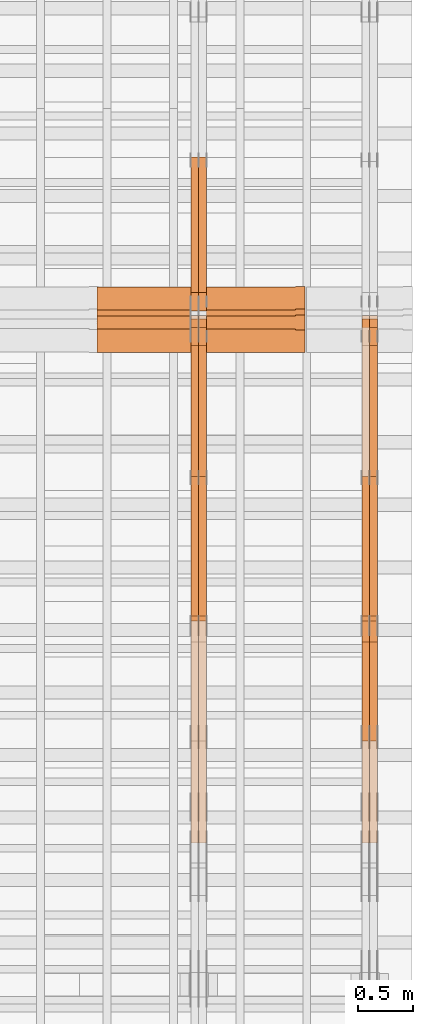
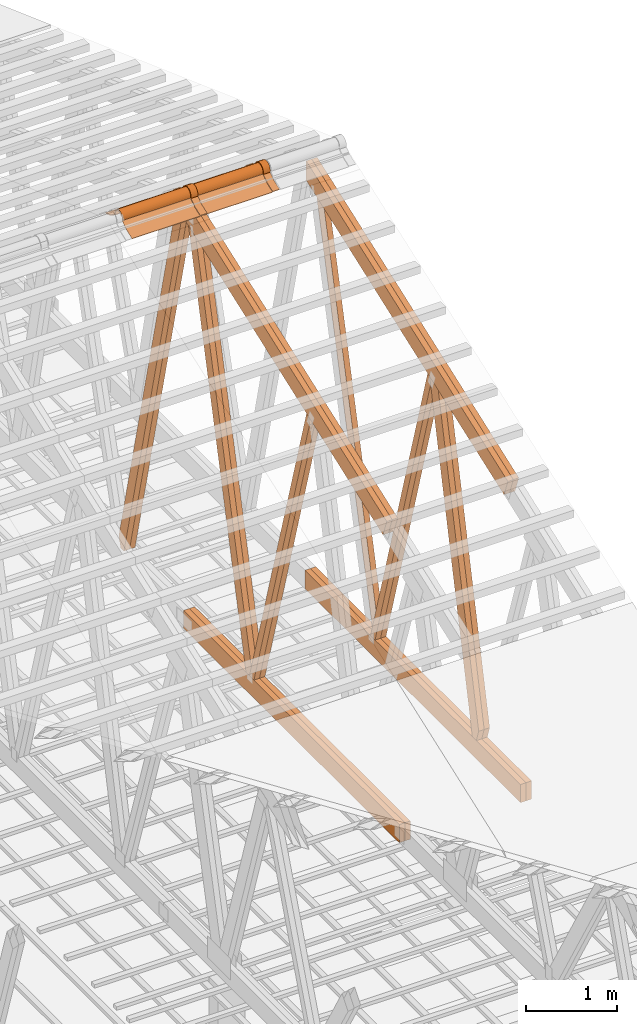
# One storey, part 56 of 189: 23 proxies.
"""IFC2X3 building model written with IfcOpenShell, lengths in millimetres."""

import ifcopenshell
import ifcopenshell.guid

model = None  # the IFC model being written
_history = None  # IfcOwnerHistory: only IFC2X3 demands one
_inside = {}  # id of a spatial element -> (the spatial element, [elements in it])
_under = {}  # id of a project, library or spatial element -> (it, [spatial elements below it])
_declared = {}  # id of a project -> (the project, [libraries it declares])
_typed = {}  # id of a type object -> (the type object, [elements of that type])
_made_of = {}  # id of a material, layer set ... -> (it, [elements and type objects made of it])


def new_model(schema):
    """Start an empty IFC model of exactly this schema.

    Asked for "IFC4X3", IfcOpenShell would pick the latest addendum, in which some entities
    have other attributes; the version numbers below select the first issue.
    IFC2X3 requires an IfcOwnerHistory on every rooted entity: one is made here for all.
    """
    global model, _history
    if schema == "IFC4X3":
        model = ifcopenshell.file(schema_version=(4, 3, 0, 0))
    else:
        model = ifcopenshell.file(schema=schema)
    _inside.clear()
    _under.clear()
    _declared.clear()
    _typed.clear()
    _made_of.clear()
    _history = None
    if model.schema == "IFC2X3":
        org = make("IfcOrganization", Name="unknown")
        user = make(
            "IfcPersonAndOrganization",
            ThePerson=make("IfcPerson", FamilyName="unknown"),
            TheOrganization=org,
        )
        app = make(
            "IfcApplication",
            ApplicationDeveloper=org,
            Version="unknown",
            ApplicationFullName="unknown",
            ApplicationIdentifier="unknown",
        )
        _history = make(
            "IfcOwnerHistory",
            OwningUser=user,
            OwningApplication=app,
            ChangeAction="ADDED",
            CreationDate=0,
        )
    return model


def make(cls, **values):
    """One entity of the class cls with the attributes given. An attribute that is None is left unset."""
    return model.create_entity(
        cls, **{name: value for name, value in values.items() if value is not None}
    )


def entity(cls, *values):
    """Any entity or typed value of the class cls, its attributes in the order of the schema. None: left unset."""
    e = model.create_entity(cls)
    for i, value in enumerate(values):
        if value is not None:
            e[i] = value
    return e


def rooted(cls, **values):
    """An entity with a GlobalId (a new one), such as an element, a storey or a relation."""
    return make(cls, GlobalId=ifcopenshell.guid.new(), OwnerHistory=_history, **values)


def si_unit(unit_type, name, prefix=None):
    """IfcSIUnit, for example si_unit("LENGTHUNIT", "METRE", prefix="MILLI")."""
    return make("IfcSIUnit", UnitType=unit_type, Prefix=prefix, Name=name)


def converted_unit(unit_type, name, factor, base, dimensions=None, offset=None):
    """IfcConversionBasedUnit, such as the inch: factor (a typed value) times the base unit."""
    return make(
        "IfcConversionBasedUnit"
        if offset is None
        else "IfcConversionBasedUnitWithOffset",
        ConversionOffset=offset,
        Dimensions=None
        if dimensions is None
        else entity("IfcDimensionalExponents", *dimensions),
        UnitType=unit_type,
        Name=name,
        ConversionFactor=make(
            "IfcMeasureWithUnit", ValueComponent=factor, UnitComponent=base
        ),
    )


def derived_unit(unit_type, elements):
    """IfcDerivedUnit: a product of units, each with its exponent."""
    return make(
        "IfcDerivedUnit",
        Elements=[
            make("IfcDerivedUnitElement", Unit=unit, Exponent=power)
            for unit, power in elements
        ],
        UnitType=unit_type,
    )


def assignment(units):
    """IfcUnitAssignment: the units of a project."""
    return None if units is None else make("IfcUnitAssignment", Units=units)


def point(xyz):
    """IfcCartesianPoint."""
    return None if xyz is None else make("IfcCartesianPoint", Coordinates=xyz)


def direction(xyz):
    """IfcDirection."""
    return None if xyz is None else make("IfcDirection", DirectionRatios=xyz)


def frame(location, z_axis=None, x_axis=None):
    """IfcAxis2Placement3D, a coordinate frame: its origin and axes. An axis left out is left unset."""
    return make(
        "IfcAxis2Placement3D",
        Location=point(location),
        Axis=direction(z_axis),
        RefDirection=direction(x_axis),
    )


def frame_2d(location, x_axis=None):
    """IfcAxis2Placement2D, a coordinate frame in the plane: its origin and x axis."""
    return make(
        "IfcAxis2Placement2D", Location=point(location), RefDirection=direction(x_axis)
    )


def origin():
    """The frame at (0, 0, 0) with its axes left unset."""
    return frame((0.0, 0.0, 0.0))


def origin_2d_with_axis():
    """The frame at (0, 0) in the plane with the x axis (1, 0) written out."""
    return frame_2d((0.0, 0.0), x_axis=(1.0, 0.0))


def place(relative_to, where):
    """IfcLocalPlacement: puts the frame where relative to a parent placement (None: the world)."""
    return make(
        "IfcLocalPlacement", PlacementRelTo=relative_to, RelativePlacement=where
    )


def context(
    kind, dimensions, precision=None, world=None, true_north=None, identifier=None
):
    """IfcGeometricRepresentationContext, for example the 3D "Model" context."""
    return make(
        "IfcGeometricRepresentationContext",
        ContextIdentifier=identifier,
        ContextType=kind,
        CoordinateSpaceDimension=dimensions,
        Precision=precision,
        WorldCoordinateSystem=world,
        TrueNorth=true_north,
    )


def subcontext(parent, identifier, kind, view, scale=None):
    """IfcGeometricRepresentationSubContext, for example "Body" below "Model"."""
    return make(
        "IfcGeometricRepresentationSubContext",
        ContextIdentifier=identifier,
        ContextType=kind,
        ParentContext=parent,
        TargetScale=scale,
        TargetView=view,
    )


def project(units=None, contexts=None):
    """IfcProject with its units and contexts."""
    return rooted(
        "IfcProject",
        Name="project",
        RepresentationContexts=contexts,
        UnitsInContext=assignment(units),
    )


def spatial(cls, under=None, at=None, **own):
    """A site, building, storey or space (cls), placed at a placement, below another one or the project."""
    s = rooted(cls, ObjectPlacement=at, **own)
    if under is not None:
        _under.setdefault(under.id(), (under, []))[1].append(s)
    return s


def polyline(points):
    """IfcPolyline through the points."""
    return make("IfcPolyline", Points=[point(p) for p in points])


def circle_curve(where, radius):
    """IfcCircle in the frame where."""
    return make("IfcCircle", Position=where, Radius=radius)


def parameter(value):
    """IfcParameterValue: where a trimmed curve begins or ends, as a parameter of its basis curve."""
    return model.create_entity("IfcParameterValue", value)


def trimmed(basis, trim1, trim2, sense, master):
    """IfcTrimmedCurve: the piece of a basis curve between two trims."""
    return make(
        "IfcTrimmedCurve",
        BasisCurve=basis,
        Trim1=trim1,
        Trim2=trim2,
        SenseAgreement=sense,
        MasterRepresentation=master,
    )


def segment(curve, same_sense, transition):
    """IfcCompositeCurveSegment."""
    return make(
        "IfcCompositeCurveSegment",
        Transition=transition,
        SameSense=same_sense,
        ParentCurve=curve,
    )


def composite_curve(segments, self_intersect=None):
    """IfcCompositeCurve: segments joined end to end."""
    return make("IfcCompositeCurve", Segments=segments, SelfIntersect=self_intersect)


def profile(cls, at=None, kind="AREA", **sizes):
    """A parametric profile (cls). Its sizes go by their IFC names, for example OverallWidth=200.0."""
    return make(cls, ProfileType=kind, Position=at, **sizes)


def rectangle(**sizes):
    """IfcRectangleProfileDef."""
    return profile("IfcRectangleProfileDef", **sizes)


def outline(outer, holes=None, kind="AREA"):
    """IfcArbitraryClosedProfileDef: a profile drawn as a closed curve; with holes, ...WithVoids."""
    if holes is None:
        return make("IfcArbitraryClosedProfileDef", ProfileType=kind, OuterCurve=outer)
    return make(
        "IfcArbitraryProfileDefWithVoids",
        ProfileType=kind,
        OuterCurve=outer,
        InnerCurves=holes,
    )


def extrude(swept, where, along, depth):
    """IfcExtrudedAreaSolid: the profile swept, set in the frame where, extruded along a direction by depth."""
    return make(
        "IfcExtrudedAreaSolid",
        SweptArea=swept,
        Position=where,
        ExtrudedDirection=direction(along),
        Depth=depth,
    )


def shape(context_of_items, identifier, shape_type, items):
    """IfcShapeRepresentation: the items that make up one representation, for example the "Body"."""
    return make(
        "IfcShapeRepresentation",
        ContextOfItems=context_of_items,
        RepresentationIdentifier=identifier,
        RepresentationType=shape_type,
        Items=items,
    )


def source(mapping_origin, context_of_items, identifier, shape_type, items):
    """IfcRepresentationMap: a shape defined once, which mapped items show again and again."""
    return make(
        "IfcRepresentationMap",
        MappingOrigin=mapping_origin,
        MappedRepresentation=shape(context_of_items, identifier, shape_type, items),
    )


def transform(
    local_origin,
    x_axis=None,
    y_axis=None,
    z_axis=None,
    scale=None,
    scale2=None,
    scale3=None,
    uniform=True,
):
    """IfcCartesianTransformationOperator3D, or its non-uniform kind. x_axis, y_axis, z_axis: its Axis1, 2, 3."""
    if uniform:
        return make(
            "IfcCartesianTransformationOperator3D",
            Axis1=direction(x_axis),
            Axis2=direction(y_axis),
            LocalOrigin=point(local_origin),
            Scale=scale,
            Axis3=direction(z_axis),
        )
    return make(
        "IfcCartesianTransformationOperator3DnonUniform",
        Axis1=direction(x_axis),
        Axis2=direction(y_axis),
        LocalOrigin=point(local_origin),
        Scale=scale,
        Axis3=direction(z_axis),
        Scale2=scale2,
        Scale3=scale3,
    )


def mapped(mapping_source, mapping_target):
    """IfcMappedItem: shows the shape of a source again, moved by a transform."""
    return make(
        "IfcMappedItem", MappingSource=mapping_source, MappingTarget=mapping_target
    )


def material(Name=None, Category=None):
    """IfcMaterial."""
    return make("IfcMaterial", Name=Name, Category=Category)


def made_of(thing, what):
    """Note that an element or type object is made of a material, layer set ...; save() writes the relation."""
    if what is not None:
        _made_of.setdefault(what.id(), (what, []))[1].append(thing)
    return thing


def type_object(cls, material=None, **own):
    """A type object (cls), such as IfcWallType, which elements share."""
    return made_of(rooted(cls, **own), material)


def type_shapes(of_type, sources):
    """Give a type object the sources (RepresentationMaps) that its elements show as mapped items."""
    of_type.RepresentationMaps = sources


def element(
    cls,
    number,
    at=None,
    inside=None,
    cuts=None,
    type_object=None,
    material=None,
    context=None,
    identifier="Body",
    shape_type=None,
    held_by="IfcProductDefinitionShape",
    body=None,
    shapes=None,
    **own,
):
    """One element of the class cls, such as IfcWall. Its Tag is "e" and its number.

    at: its placement. inside: the storey or other place that contains it. cuts: it is an
    opening in that element (IfcRelVoidsElement). A single representation is given by context,
    identifier, shape_type and body (its items); several are given by shapes. held_by: the class
    of the entity that holds the representations. save() writes the other relations.
    """
    e = rooted(cls, Tag="e%d" % number, ObjectPlacement=at, **own)
    if body is not None:
        shapes = [shape(context, identifier, shape_type, body)]
    if shapes is not None:
        e.Representation = make(held_by, Representations=shapes)
    if inside is not None:
        _inside.setdefault(inside.id(), (inside, []))[1].append(e)
    if cuts is not None:
        rooted(
            "IfcRelVoidsElement", RelatingBuildingElement=cuts, RelatedOpeningElement=e
        )
    if type_object is not None:
        _typed.setdefault(type_object.id(), (type_object, []))[1].append(e)
    return made_of(e, material)


def aggregate(whole, parts):
    """IfcRelAggregates: a whole, such as a stair, and the parts it consists of."""
    return rooted("IfcRelAggregates", RelatingObject=whole, RelatedObjects=parts)


def save(model, path):
    """Write the relations noted so far, then the file.

    IfcRelAggregates (storeys below a building ...), IfcRelContainedInSpatialStructure (elements
    in a storey), IfcRelDefinesByType, IfcRelAssociatesMaterial and IfcRelDeclares: one each for
    every whole, place, type object, material and project.
    """
    for whole, parts in _under.values():
        aggregate(whole, parts)
    for where, things in _inside.values():
        rooted(
            "IfcRelContainedInSpatialStructure",
            RelatedElements=things,
            RelatingStructure=where,
        )
    for kind, things in _typed.values():
        rooted("IfcRelDefinesByType", RelatedObjects=things, RelatingType=kind)
    for what, things in _made_of.values():
        rooted("IfcRelAssociatesMaterial", RelatedObjects=things, RelatingMaterial=what)
    for by, libraries in _declared.values():
        rooted("IfcRelDeclares", RelatingContext=by, RelatedDefinitions=libraries)
    model.write(path)


model = new_model("IFC2X3")

# Units and contexts
model_context = context("Model", 3, precision=0.01, world=origin(), true_north=direction((6.12303176911189e-17, 1.0)))
body_context = subcontext(model_context, "Body", "Model", "MODEL_VIEW")
ifc_project = project(units=[si_unit("LENGTHUNIT", "METRE", prefix="MILLI"), si_unit("AREAUNIT", "SQUARE_METRE"), si_unit("VOLUMEUNIT", "CUBIC_METRE"), converted_unit("PLANEANGLEUNIT", "DEGREE", entity("IfcRatioMeasure", 0.0174532925199433), si_unit("PLANEANGLEUNIT", "RADIAN"), dimensions=[0, 0, 0, 0, 0, 0, 0]), si_unit("MASSUNIT", "GRAM", prefix="KILO"), derived_unit("MASSDENSITYUNIT", [(si_unit("MASSUNIT", "GRAM", prefix="KILO"), 1), (si_unit("LENGTHUNIT", "METRE"), -3)]), si_unit("TIMEUNIT", "SECOND"), si_unit("FREQUENCYUNIT", "HERTZ"), si_unit("THERMODYNAMICTEMPERATUREUNIT", "DEGREE_CELSIUS"), derived_unit("THERMALTRANSMITTANCEUNIT", [(si_unit("MASSUNIT", "GRAM", prefix="KILO"), 1), (si_unit("THERMODYNAMICTEMPERATUREUNIT", "KELVIN"), -1), (si_unit("TIMEUNIT", "SECOND"), -3)]), derived_unit("VOLUMETRICFLOWRATEUNIT", [(si_unit("LENGTHUNIT", "METRE"), 3), (si_unit("TIMEUNIT", "SECOND"), -1)]), si_unit("ELECTRICCURRENTUNIT", "AMPERE"), si_unit("ELECTRICVOLTAGEUNIT", "VOLT"), si_unit("POWERUNIT", "WATT"), si_unit("FORCEUNIT", "NEWTON"), si_unit("ILLUMINANCEUNIT", "LUX"), si_unit("LUMINOUSFLUXUNIT", "LUMEN"), si_unit("LUMINOUSINTENSITYUNIT", "CANDELA"), derived_unit("USERDEFINED", [(si_unit("MASSUNIT", "GRAM", prefix="KILO"), -1), (si_unit("LENGTHUNIT", "METRE"), -2), (si_unit("TIMEUNIT", "SECOND"), 3), (si_unit("LUMINOUSFLUXUNIT", "LUMEN"), 1)]), derived_unit("LINEARVELOCITYUNIT", [(si_unit("LENGTHUNIT", "METRE"), 1), (si_unit("TIMEUNIT", "SECOND"), -1)]), si_unit("PRESSUREUNIT", "PASCAL"), derived_unit("USERDEFINED", [(si_unit("LENGTHUNIT", "METRE"), -2), (si_unit("MASSUNIT", "GRAM", prefix="KILO"), 1), (si_unit("TIMEUNIT", "SECOND"), -2)])], contexts=[model_context])

# Site, building, storey
site_placement = place(None, origin())
site = spatial("IfcSite", under=ifc_project, at=site_placement, CompositionType="ELEMENT")
building_placement = place(site_placement, origin())
building = spatial("IfcBuilding", under=site, at=building_placement, CompositionType="ELEMENT")
storey_placement = place(building_placement, origin())
storey = spatial("IfcBuildingStorey", under=building, at=storey_placement, Name="Default", CompositionType="ELEMENT", Elevation=0.0)

# Proxies
ifc_material_1 = material(Name="IfcSurfaceStyle #273904")
building_element_proxy_type_1 = type_object("IfcBuildingElementProxyType", Name="T1-W5 273902", PredefinedType="NOTDEFINED", material=ifc_material_1)
shared_shape_1 = source(origin(), body_context, "Body", "SweptSolid", [
    extrude(outline(polyline([(-3233.61216530572, -72.4999091305202), (2153.79187521892, -72.4999091305202), (2171.36968478227, -7.18521572819375e-05), (2045.62106208646, 72.4999450565989), (-3137.17045678193, 72.4999450565989), (-3233.61216530572, -72.4999091305202)])), frame((2171.36968478227, 72.500192121173, 0.0), z_axis=(0.0, 0.0, 1.0), x_axis=(-1.0, 0.0, 0.0)), (0.0, 0.0, 1.0), 69.9999999999997),
])
type_shapes(building_element_proxy_type_1, [shared_shape_1])
proxy_1_placement = place(building_placement, frame((49840.0, 13261.0146935344, 262.082919891325), z_axis=(-1.0, 0.0, 0.0), x_axis=(0.0, 0.235625623344066, 0.97184389982328)))
element("IfcBuildingElementProxy", 1, at=proxy_1_placement, inside=storey, type_object=building_element_proxy_type_1, material=ifc_material_1, Name="T1-W5", context=body_context, shape_type="MappedRepresentation", body=[
    mapped(shared_shape_1, transform((0.0, 0.0, 0.0), scale=1.0)),
])
ifc_material_2 = material(Name="IfcSurfaceStyle #273640")
building_element_proxy_type_2 = type_object("IfcBuildingElementProxyType", Name="T1-W6 273638", PredefinedType="NOTDEFINED", material=ifc_material_2)
shared_shape_2 = source(origin(), body_context, "Body", "SweptSolid", [
    extrude(outline(polyline([(-2640.84340836012, -47.4996765865792), (1711.12245024294, -47.4996765865792), (1797.68490303083, -9.57690019346202e-05), (1800.72595169379, 47.4997244710801), (-2668.68989660745, 47.4997244710801), (-2640.84340836012, -47.4996765865792)])), frame((1800.72595169379, 47.5003009358159, 0.0), z_axis=(0.0, 0.0, 1.0), x_axis=(-1.0, 0.0, 0.0)), (0.0, 0.0, 1.0), 69.9999999999997),
])
type_shapes(building_element_proxy_type_2, [shared_shape_2])
proxy_2_placement = place(building_placement, frame((49840.0, 12074.2896156894, 4533.9586582452), z_axis=(-1.0, 0.0, 0.0), x_axis=(0.0, 0.28128598310461, -0.959623986626467)))
element("IfcBuildingElementProxy", 2, at=proxy_2_placement, inside=storey, type_object=building_element_proxy_type_2, material=ifc_material_2, Name="T1-W6", context=body_context, shape_type="MappedRepresentation", body=[
    mapped(shared_shape_2, transform((0.0, 0.0, 0.0), scale=1.0)),
])
ifc_material_3 = material(Name="IfcSurfaceStyle #273574")
building_element_proxy_type_3 = type_object("IfcBuildingElementProxyType", Name="T1-W6 273572", PredefinedType="NOTDEFINED", material=ifc_material_3)
shared_shape_3 = source(origin(), body_context, "Body", "SweptSolid", [
    extrude(outline(polyline([(-2640.84340836012, -47.4996765865792), (1711.12245024294, -47.4996765865792), (1797.68490303083, -9.57690019346202e-05), (1800.72595169379, 47.4997244710801), (-2668.68989660745, 47.4997244710801), (-2640.84340836012, -47.4996765865792)])), frame((1800.72595169379, 47.5003009358159, 0.0), z_axis=(0.0, 0.0, 1.0), x_axis=(-1.0, 0.0, 0.0)), (0.0, 0.0, 1.0), 69.9999999999997),
])
type_shapes(building_element_proxy_type_3, [shared_shape_3])
proxy_3_placement = place(building_placement, frame((49770.0, 12074.2896156894, 4533.9586582452), z_axis=(-1.0, 0.0, 0.0), x_axis=(0.0, 0.28128598310461, -0.959623986626467)))
element("IfcBuildingElementProxy", 3, at=proxy_3_placement, inside=storey, type_object=building_element_proxy_type_3, material=ifc_material_3, Name="T1-W6", context=body_context, shape_type="MappedRepresentation", body=[
    mapped(shared_shape_3, transform((0.0, 0.0, 0.0), scale=1.0)),
])
ifc_material_4 = material(Name="IfcSurfaceStyle #273376")
building_element_proxy_type_4 = type_object("IfcBuildingElementProxyType", Name="T1-W3 273374", PredefinedType="NOTDEFINED", material=ifc_material_4)
shared_shape_4 = source(origin(), body_context, "Body", "SweptSolid", [
    extrude(outline(polyline([(-2625.55080717397, -84.9998286237256), (1749.48871563991, -84.9998286237256), (1768.20584427244, 0.000602085469291858), (1625.445846867, 85.0000405971208), (-2517.58959960538, 84.9990145648612), (-2625.55080717397, -84.9998286237256)])), frame((1768.20584427244, 85.0000405971208, 0.0), z_axis=(0.0, 0.0, 1.0), x_axis=(-1.0, 0.0, 0.0)), (0.0, 0.0, 1.0), 69.9999999999997),
])
type_shapes(building_element_proxy_type_4, [shared_shape_4])
proxy_4_placement = place(building_placement, frame((49840.0, 10918.6728403286, 263.278932236374), z_axis=(-1.0, 0.0, 0.0), x_axis=(0.0, 0.215047682154604, 0.976603550269982)))
element("IfcBuildingElementProxy", 4, at=proxy_4_placement, inside=storey, type_object=building_element_proxy_type_4, material=ifc_material_4, Name="T1-W3", context=body_context, shape_type="MappedRepresentation", body=[
    mapped(shared_shape_4, transform((0.0, 0.0, 0.0), scale=1.0)),
])
ifc_material_5 = material(Name="IfcSurfaceStyle #273310")
building_element_proxy_type_5 = type_object("IfcBuildingElementProxyType", Name="T1-W3 273308", PredefinedType="NOTDEFINED", material=ifc_material_5)
shared_shape_5 = source(origin(), body_context, "Body", "SweptSolid", [
    extrude(outline(polyline([(-2625.55080717397, -84.9998286237256), (1749.48871563991, -84.9998286237256), (1768.20584427244, 0.000602085469291858), (1625.445846867, 85.0000405971208), (-2517.58959960538, 84.9990145648612), (-2625.55080717397, -84.9998286237256)])), frame((1768.20584427244, 85.0000405971208, 0.0), z_axis=(0.0, 0.0, 1.0), x_axis=(-1.0, 0.0, 0.0)), (0.0, 0.0, 1.0), 69.9999999999997),
])
type_shapes(building_element_proxy_type_5, [shared_shape_5])
proxy_5_placement = place(building_placement, frame((49770.0, 10918.6728403286, 263.278932236374), z_axis=(-1.0, 0.0, 0.0), x_axis=(0.0, 0.215047682154604, 0.976603550269982)))
element("IfcBuildingElementProxy", 5, at=proxy_5_placement, inside=storey, type_object=building_element_proxy_type_5, material=ifc_material_5, Name="T1-W3", context=body_context, shape_type="MappedRepresentation", body=[
    mapped(shared_shape_5, transform((0.0, 0.0, 0.0), scale=1.0)),
])
ifc_material_6 = material(Name="IfcSurfaceStyle #269620")
building_element_proxy_type_6 = type_object("IfcBuildingElementProxyType", Name="T1-B3 269618", PredefinedType="NOTDEFINED", material=ifc_material_6)
shared_shape_6 = source(origin(), body_context, "Body", "SweptSolid", [
    extrude(rectangle(XDim=4751.0283203125, YDim=245.000000000001, at=origin_2d_with_axis()), frame((2375.51416015625, 122.5, 0.0), z_axis=(0.0, 0.0, 1.0), x_axis=(-1.0, 0.0, 0.0)), (0.0, 0.0, 1.0), 69.9999999999997),
])
type_shapes(building_element_proxy_type_6, [shared_shape_6])
proxy_6_placement = place(building_placement, frame((49840.0, 10029.23046875, 245.0), z_axis=(-1.0, 0.0, 0.0), x_axis=(0.0, 1.0, 0.0)))
element("IfcBuildingElementProxy", 6, at=proxy_6_placement, inside=storey, type_object=building_element_proxy_type_6, material=ifc_material_6, Name="T1-B3", context=body_context, shape_type="MappedRepresentation", body=[
    mapped(shared_shape_6, transform((0.0, 0.0, 0.0), scale=1.0)),
])
ifc_material_7 = material(Name="IfcSurfaceStyle #269563")
building_element_proxy_type_7 = type_object("IfcBuildingElementProxyType", Name="T1-B3 269561", PredefinedType="NOTDEFINED", material=ifc_material_7)
shared_shape_7 = source(origin(), body_context, "Body", "SweptSolid", [
    extrude(rectangle(XDim=4751.0283203125, YDim=245.000000000001, at=origin_2d_with_axis()), frame((2375.51416015625, 122.5, 0.0), z_axis=(0.0, 0.0, 1.0), x_axis=(-1.0, 0.0, 0.0)), (0.0, 0.0, 1.0), 69.9999999999997),
])
type_shapes(building_element_proxy_type_7, [shared_shape_7])
proxy_7_placement = place(building_placement, frame((49770.0, 10029.23046875, 245.0), z_axis=(-1.0, 0.0, 0.0), x_axis=(0.0, 1.0, 0.0)))
element("IfcBuildingElementProxy", 7, at=proxy_7_placement, inside=storey, type_object=building_element_proxy_type_7, material=ifc_material_7, Name="T1-B3", context=body_context, shape_type="MappedRepresentation", body=[
    mapped(shared_shape_7, transform((0.0, 0.0, 0.0), scale=1.0)),
])
ifc_material_8 = material(Name="IfcSurfaceStyle #269032")
building_element_proxy_type_8 = type_object("IfcBuildingElementProxyType", Name="T1-T3 269030", PredefinedType="NOTDEFINED", material=ifc_material_8)
shared_shape_8 = source(origin(), body_context, "Body", "SweptSolid", [
    extrude(outline(polyline([(-2341.64890001385, -122.499972785692), (2386.23525922045, -122.499972785692), (2297.06252495753, 122.499972785692), (-2341.64888416412, 122.499972785692), (-2341.64890001385, -122.499972785692)])), frame((2386.23525922045, 122.499973888764, 0.0), z_axis=(0.0, 0.0, 1.0), x_axis=(-1.0, 0.0, 0.0)), (0.0, 0.0, 1.0), 69.9999999999997),
])
type_shapes(building_element_proxy_type_8, [shared_shape_8])
proxy_8_placement = place(building_placement, frame((49840.0, 14833.7949607394, 5538.33627266055), z_axis=(-1.0, 0.0, 0.0), x_axis=(0.0, -0.939692620785908, -0.342020143325669)))
element("IfcBuildingElementProxy", 8, at=proxy_8_placement, inside=storey, type_object=building_element_proxy_type_8, material=ifc_material_8, Name="T1-T3", context=body_context, shape_type="MappedRepresentation", body=[
    mapped(shared_shape_8, transform((0.0, 0.0, 0.0), scale=1.0)),
])
ifc_material_9 = material(Name="IfcSurfaceStyle #268975")
building_element_proxy_type_9 = type_object("IfcBuildingElementProxyType", Name="T1-T3 268973", PredefinedType="NOTDEFINED", material=ifc_material_9)
shared_shape_9 = source(origin(), body_context, "Body", "SweptSolid", [
    extrude(outline(polyline([(-2341.64890001385, -122.499972785692), (2386.23525922045, -122.499972785692), (2297.06252495753, 122.499972785692), (-2341.64888416412, 122.499972785692), (-2341.64890001385, -122.499972785692)])), frame((2386.23525922045, 122.499973888764, 0.0), z_axis=(0.0, 0.0, 1.0), x_axis=(-1.0, 0.0, 0.0)), (0.0, 0.0, 1.0), 69.9999999999997),
])
type_shapes(building_element_proxy_type_9, [shared_shape_9])
proxy_9_placement = place(building_placement, frame((49770.0, 14833.7949607394, 5538.33627266055), z_axis=(-1.0, 0.0, 0.0), x_axis=(0.0, -0.939692620785908, -0.342020143325669)))
element("IfcBuildingElementProxy", 9, at=proxy_9_placement, inside=storey, type_object=building_element_proxy_type_9, material=ifc_material_9, Name="T1-T3", context=body_context, shape_type="MappedRepresentation", body=[
    mapped(shared_shape_9, transform((0.0, 0.0, 0.0), scale=1.0)),
])
ifc_material_10 = material(Name="IfcSurfaceStyle #258114")
building_element_proxy_type_10 = type_object("IfcBuildingElementProxyType", Name="T1-W5 258112", PredefinedType="NOTDEFINED", material=ifc_material_10)
shared_shape_10 = source(origin(), body_context, "Body", "SweptSolid", [
    extrude(outline(polyline([(-3233.61216530572, -72.4999091305202), (2153.79187521892, -72.4999091305202), (2171.36968478227, -7.18521572819375e-05), (2045.62106208646, 72.4999450565989), (-3137.17045678193, 72.4999450565989), (-3233.61216530572, -72.4999091305202)])), frame((2171.36968478227, 72.500192121173, 0.0), z_axis=(0.0, 0.0, 1.0), x_axis=(-1.0, 0.0, 0.0)), (0.0, 0.0, 1.0), 69.9999999999997),
])
type_shapes(building_element_proxy_type_10, [shared_shape_10])
proxy_10_placement = place(building_placement, frame((48300.0, 13261.0146935344, 262.082919891325), z_axis=(-1.0, 0.0, 0.0), x_axis=(0.0, 0.235625623344066, 0.97184389982328)))
element("IfcBuildingElementProxy", 10, at=proxy_10_placement, inside=storey, type_object=building_element_proxy_type_10, material=ifc_material_10, Name="T1-W5", context=body_context, shape_type="MappedRepresentation", body=[
    mapped(shared_shape_10, transform((0.0, 0.0, 0.0), scale=1.0)),
])
ifc_material_11 = material(Name="IfcSurfaceStyle #258048")
building_element_proxy_type_11 = type_object("IfcBuildingElementProxyType", Name="T1-W5 258046", PredefinedType="NOTDEFINED", material=ifc_material_11)
shared_shape_11 = source(origin(), body_context, "Body", "SweptSolid", [
    extrude(outline(polyline([(-3233.61216530572, -72.4999091305202), (2153.79187521892, -72.4999091305202), (2171.36968478227, -7.18521572819375e-05), (2045.62106208646, 72.4999450565989), (-3137.17045678193, 72.4999450565989), (-3233.61216530572, -72.4999091305202)])), frame((2171.36968478227, 72.500192121173, 0.0), z_axis=(0.0, 0.0, 1.0), x_axis=(-1.0, 0.0, 0.0)), (0.0, 0.0, 1.0), 69.9999999999997),
])
type_shapes(building_element_proxy_type_11, [shared_shape_11])
proxy_11_placement = place(building_placement, frame((48230.0, 13261.0146935344, 262.082919891325), z_axis=(-1.0, 0.0, 0.0), x_axis=(0.0, 0.235625623344066, 0.97184389982328)))
element("IfcBuildingElementProxy", 11, at=proxy_11_placement, inside=storey, type_object=building_element_proxy_type_11, material=ifc_material_11, Name="T1-W5", context=body_context, shape_type="MappedRepresentation", body=[
    mapped(shared_shape_11, transform((0.0, 0.0, 0.0), scale=1.0)),
])
ifc_material_12 = material(Name="IfcSurfaceStyle #257982")
building_element_proxy_type_12 = type_object("IfcBuildingElementProxyType", Name="T1-W5 257980", PredefinedType="NOTDEFINED", material=ifc_material_12)
shared_shape_12 = source(origin(), body_context, "Body", "SweptSolid", [
    extrude(outline(polyline([(-3137.17045678193, -72.5002081306407), (2045.62106208646, -72.5002081306408), (2171.36968478227, 5.58426931168476e-05), (2153.79187521892, 72.5001802092942), (-3233.61216530572, 72.5001802092942), (-3137.17045678193, -72.5002081306407)])), frame((2171.36968478227, 72.5001802092942, 0.0), z_axis=(0.0, 0.0, 1.0), x_axis=(-1.0, 0.0, 0.0)), (0.0, 0.0, 1.0), 69.9999999999997),
])
type_shapes(building_element_proxy_type_12, [shared_shape_12])
proxy_12_placement = place(building_placement, frame((48300.0, 16098.0675635854, 227.917113003597), z_axis=(-1.0, 0.0, 0.0), x_axis=(0.0, -0.235625623344066, 0.971843899823279)))
element("IfcBuildingElementProxy", 12, at=proxy_12_placement, inside=storey, type_object=building_element_proxy_type_12, material=ifc_material_12, Name="T1-W5", context=body_context, shape_type="MappedRepresentation", body=[
    mapped(shared_shape_12, transform((0.0, 0.0, 0.0), scale=1.0)),
])
ifc_material_13 = material(Name="IfcSurfaceStyle #257916")
building_element_proxy_type_13 = type_object("IfcBuildingElementProxyType", Name="T1-W5 257914", PredefinedType="NOTDEFINED", material=ifc_material_13)
shared_shape_13 = source(origin(), body_context, "Body", "SweptSolid", [
    extrude(outline(polyline([(-3137.17045678193, -72.5002081306407), (2045.62106208646, -72.5002081306408), (2171.36968478227, 5.58426931168476e-05), (2153.79187521892, 72.5001802092942), (-3233.61216530572, 72.5001802092942), (-3137.17045678193, -72.5002081306407)])), frame((2171.36968478227, 72.5001802092942, 0.0), z_axis=(0.0, 0.0, 1.0), x_axis=(-1.0, 0.0, 0.0)), (0.0, 0.0, 1.0), 69.9999999999997),
])
type_shapes(building_element_proxy_type_13, [shared_shape_13])
proxy_13_placement = place(building_placement, frame((48230.0, 16098.0675635854, 227.917113003597), z_axis=(-1.0, 0.0, 0.0), x_axis=(0.0, -0.235625623344066, 0.971843899823279)))
element("IfcBuildingElementProxy", 13, at=proxy_13_placement, inside=storey, type_object=building_element_proxy_type_13, material=ifc_material_13, Name="T1-W5", context=body_context, shape_type="MappedRepresentation", body=[
    mapped(shared_shape_13, transform((0.0, 0.0, 0.0), scale=1.0)),
])
ifc_material_14 = material(Name="IfcSurfaceStyle #257850")
building_element_proxy_type_14 = type_object("IfcBuildingElementProxyType", Name="T1-W6 257848", PredefinedType="NOTDEFINED", material=ifc_material_14)
shared_shape_14 = source(origin(), body_context, "Body", "SweptSolid", [
    extrude(outline(polyline([(-2640.84340836012, -47.4996765865792), (1711.12245024294, -47.4996765865792), (1797.68490303083, -9.57690019346202e-05), (1800.72595169379, 47.4997244710801), (-2668.68989660745, 47.4997244710801), (-2640.84340836012, -47.4996765865792)])), frame((1800.72595169379, 47.5003009358159, 0.0), z_axis=(0.0, 0.0, 1.0), x_axis=(-1.0, 0.0, 0.0)), (0.0, 0.0, 1.0), 69.9999999999997),
])
type_shapes(building_element_proxy_type_14, [shared_shape_14])
proxy_14_placement = place(building_placement, frame((48300.0, 12074.2896156894, 4533.9586582452), z_axis=(-1.0, 0.0, 0.0), x_axis=(0.0, 0.28128598310461, -0.959623986626467)))
element("IfcBuildingElementProxy", 14, at=proxy_14_placement, inside=storey, type_object=building_element_proxy_type_14, material=ifc_material_14, Name="T1-W6", context=body_context, shape_type="MappedRepresentation", body=[
    mapped(shared_shape_14, transform((0.0, 0.0, 0.0), scale=1.0)),
])
ifc_material_15 = material(Name="IfcSurfaceStyle #257784")
building_element_proxy_type_15 = type_object("IfcBuildingElementProxyType", Name="T1-W6 257782", PredefinedType="NOTDEFINED", material=ifc_material_15)
shared_shape_15 = source(origin(), body_context, "Body", "SweptSolid", [
    extrude(outline(polyline([(-2640.84340836012, -47.4996765865792), (1711.12245024294, -47.4996765865792), (1797.68490303083, -9.57690019346202e-05), (1800.72595169379, 47.4997244710801), (-2668.68989660745, 47.4997244710801), (-2640.84340836012, -47.4996765865792)])), frame((1800.72595169379, 47.5003009358159, 0.0), z_axis=(0.0, 0.0, 1.0), x_axis=(-1.0, 0.0, 0.0)), (0.0, 0.0, 1.0), 69.9999999999997),
])
type_shapes(building_element_proxy_type_15, [shared_shape_15])
proxy_15_placement = place(building_placement, frame((48230.0, 12074.2896156894, 4533.9586582452), z_axis=(-1.0, 0.0, 0.0), x_axis=(0.0, 0.28128598310461, -0.959623986626467)))
element("IfcBuildingElementProxy", 15, at=proxy_15_placement, inside=storey, type_object=building_element_proxy_type_15, material=ifc_material_15, Name="T1-W6", context=body_context, shape_type="MappedRepresentation", body=[
    mapped(shared_shape_15, transform((0.0, 0.0, 0.0), scale=1.0)),
])
ifc_material_16 = material(Name="IfcSurfaceStyle #253830")
building_element_proxy_type_16 = type_object("IfcBuildingElementProxyType", Name="T1-B3 253828", PredefinedType="NOTDEFINED", material=ifc_material_16)
shared_shape_16 = source(origin(), body_context, "Body", "SweptSolid", [
    extrude(rectangle(XDim=4751.0283203125, YDim=245.000000000001, at=origin_2d_with_axis()), frame((2375.51416015625, 122.5, 0.0), z_axis=(0.0, 0.0, 1.0), x_axis=(-1.0, 0.0, 0.0)), (0.0, 0.0, 1.0), 69.9999999999997),
])
type_shapes(building_element_proxy_type_16, [shared_shape_16])
proxy_16_placement = place(building_placement, frame((48300.0, 10029.23046875, 245.0), z_axis=(-1.0, 0.0, 0.0), x_axis=(0.0, 1.0, 0.0)))
element("IfcBuildingElementProxy", 16, at=proxy_16_placement, inside=storey, type_object=building_element_proxy_type_16, material=ifc_material_16, Name="T1-B3", context=body_context, shape_type="MappedRepresentation", body=[
    mapped(shared_shape_16, transform((0.0, 0.0, 0.0), scale=1.0)),
])
ifc_material_17 = material(Name="IfcSurfaceStyle #253773")
building_element_proxy_type_17 = type_object("IfcBuildingElementProxyType", Name="T1-B3 253771", PredefinedType="NOTDEFINED", material=ifc_material_17)
shared_shape_17 = source(origin(), body_context, "Body", "SweptSolid", [
    extrude(rectangle(XDim=4751.0283203125, YDim=245.000000000001, at=origin_2d_with_axis()), frame((2375.51416015625, 122.5, 0.0), z_axis=(0.0, 0.0, 1.0), x_axis=(-1.0, 0.0, 0.0)), (0.0, 0.0, 1.0), 69.9999999999997),
])
type_shapes(building_element_proxy_type_17, [shared_shape_17])
proxy_17_placement = place(building_placement, frame((48230.0, 10029.23046875, 245.0), z_axis=(-1.0, 0.0, 0.0), x_axis=(0.0, 1.0, 0.0)))
element("IfcBuildingElementProxy", 17, at=proxy_17_placement, inside=storey, type_object=building_element_proxy_type_17, material=ifc_material_17, Name="T1-B3", context=body_context, shape_type="MappedRepresentation", body=[
    mapped(shared_shape_17, transform((0.0, 0.0, 0.0), scale=1.0)),
])
ifc_material_18 = material(Name="IfcSurfaceStyle #253242")
building_element_proxy_type_18 = type_object("IfcBuildingElementProxyType", Name="T1-T3 253240", PredefinedType="NOTDEFINED", material=ifc_material_18)
shared_shape_18 = source(origin(), body_context, "Body", "SweptSolid", [
    extrude(outline(polyline([(-2341.64890001385, -122.499972785692), (2386.23525922045, -122.499972785692), (2297.06252495753, 122.499972785692), (-2341.64888416412, 122.499972785692), (-2341.64890001385, -122.499972785692)])), frame((2386.23525922045, 122.499973888764, 0.0), z_axis=(0.0, 0.0, 1.0), x_axis=(-1.0, 0.0, 0.0)), (0.0, 0.0, 1.0), 69.9999999999997),
])
type_shapes(building_element_proxy_type_18, [shared_shape_18])
proxy_18_placement = place(building_placement, frame((48300.0, 14833.7949607394, 5538.33627266055), z_axis=(-1.0, 0.0, 0.0), x_axis=(0.0, -0.939692620785908, -0.342020143325669)))
element("IfcBuildingElementProxy", 18, at=proxy_18_placement, inside=storey, type_object=building_element_proxy_type_18, material=ifc_material_18, Name="T1-T3", context=body_context, shape_type="MappedRepresentation", body=[
    mapped(shared_shape_18, transform((0.0, 0.0, 0.0), scale=1.0)),
])
ifc_material_19 = material(Name="IfcSurfaceStyle #253185")
building_element_proxy_type_19 = type_object("IfcBuildingElementProxyType", Name="T1-T3 253183", PredefinedType="NOTDEFINED", material=ifc_material_19)
shared_shape_19 = source(origin(), body_context, "Body", "SweptSolid", [
    extrude(outline(polyline([(-2341.64890001385, -122.499972785692), (2386.23525922045, -122.499972785692), (2297.06252495753, 122.499972785692), (-2341.64888416412, 122.499972785692), (-2341.64890001385, -122.499972785692)])), frame((2386.23525922045, 122.499973888764, 0.0), z_axis=(0.0, 0.0, 1.0), x_axis=(-1.0, 0.0, 0.0)), (0.0, 0.0, 1.0), 69.9999999999997),
])
type_shapes(building_element_proxy_type_19, [shared_shape_19])
proxy_19_placement = place(building_placement, frame((48230.0, 14833.7949607394, 5538.33627266055), z_axis=(-1.0, 0.0, 0.0), x_axis=(0.0, -0.939692620785908, -0.342020143325669)))
element("IfcBuildingElementProxy", 19, at=proxy_19_placement, inside=storey, type_object=building_element_proxy_type_19, material=ifc_material_19, Name="T1-T3", context=body_context, shape_type="MappedRepresentation", body=[
    mapped(shared_shape_19, transform((0.0, 0.0, 0.0), scale=1.0)),
])
ifc_material_20 = material()
building_element_proxy_type_20 = type_object("IfcBuildingElementProxyType", Name="P75", PredefinedType="NOTDEFINED", material=ifc_material_20)
shared_shape_20 = source(origin(), body_context, "Body", "SweptSolid", [
    extrude(outline(composite_curve([segment(polyline([(-69.4623915065845, -4.60763114971976), (47.4521071665907, -4.60763114971981)]), True, "CONTINUOUS"), segment(trimmed(circle_curve(frame_2d((119.940978060963, 14.6372018310859), x_axis=(-0.966518278591622, -0.256597773077395)), 75.0), [parameter(6.61555373744412e-13)], [parameter(180.0)], True, "PARAMETER"), True, "CONTINUOUS"), segment(polyline([(192.429848955335, 33.882034811891), (182.764666169419, 31.3160570811166)]), True, "CONTINUOUS"), segment(trimmed(circle_curve(frame_2d((119.940978060963, 14.6372018310859), x_axis=(-0.966518278591622, -0.256597773077395)), 65.0), [parameter(1.06866637297174e-12)], [parameter(180.0)], True, "PARAMETER"), False, "CONTINUOUS"), segment(polyline([(57.1172899525073, -2.04165341894578), (47.4521071665911, 5.39236885028051)]), True, "CONTINUOUS"), segment(polyline([(47.4521071665911, 5.39236885028052), (-70.7672243976422, 5.39236885028094)]), True, "CONTINUOUS"), segment(polyline([(-70.7672243976422, 5.39236885028094), (-194.776190618495, -27.5303655446341)]), True, "CONTINUOUS"), segment(polyline([(-194.776190618495, -27.5303655446341), (-192.210212887721, -37.1955483305503)]), True, "CONTINUOUS"), segment(polyline([(-192.210212887721, -37.1955483305503), (-69.4623915065845, -4.60763114971974)]), True, "CONTINUOUS")], self_intersect=False)), frame((0.0, 106.775760402721, -56.5599052870917), z_axis=(1.0, 0.0, 0.0), x_axis=(0.0, -0.820468487122275, 0.571691754041709)), (0.0, 0.0, 1.0), 867.000000000001),
    extrude(outline(composite_curve([segment(polyline([(62.2906866429439, -18.428943356533), (189.290686642944, -18.428943356533)]), True, "CONTINUOUS"), segment(polyline([(189.290686642944, -18.428943356533), (189.290686642944, -8.42894335653292)]), True, "CONTINUOUS"), segment(polyline([(189.290686642944, -8.42894335653292), (62.2906866429439, -8.42894335653294)]), True, "CONTINUOUS"), segment(polyline([(62.2906866429439, -8.42894335653294), (-41.0348065006093, 19.0026034957362)]), True, "CONTINUOUS"), segment(trimmed(circle_curve(frame_2d((-125.709313357056, 11.5710566434651), x_axis=(1.0, 0.0)), 85.0), [parameter(5.01577186738723)], [parameter(180.0)], True, "PARAMETER"), True, "CONTINUOUS"), segment(polyline([(-210.709313357056, 11.5710566434656), (-200.709313357056, 11.5710566434656)]), True, "CONTINUOUS"), segment(trimmed(circle_curve(frame_2d((-125.709313357056, 11.5710566434651), x_axis=(1.0, 0.0)), 75.0), [parameter(3.05333249420498e-13)], [parameter(180.0)], True, "PARAMETER"), False, "CONTINUOUS"), segment(polyline([(-50.7093133570542, 11.5710566434655), (62.290686642944, -18.4289433565322)]), True, "CONTINUOUS")], self_intersect=False)), frame((867.0, 114.170579674061, -53.8683539143053), z_axis=(1.0, 0.0, 0.0), x_axis=(0.0, 0.939692620785914, -0.342020143325653)), (0.0, 0.0, 1.0), 86.9999999999998),
])
type_shapes(building_element_proxy_type_20, [shared_shape_20])
for number, where, name in (
    (20, (48232.9353253273, 14755.0000438631, 5865.69618295448), "P75, generic model20:P75"),
    (21, (47312.9353253273, 14755.0000438631, 5865.69618295448), "P75, generic model20:P75"),
):
    element("IfcBuildingElementProxy", number, at=place(storey_placement, frame(where)), inside=storey, type_object=building_element_proxy_type_20, material=ifc_material_20, Name=name, ObjectType="P75, generic model20:P75", context=body_context, shape_type="MappedRepresentation", body=[
        mapped(shared_shape_20, transform((0.0, 0.0, 0.0), scale=1.0)),
    ])
building_element_proxy_type_21 = type_object("IfcBuildingElementProxyType", Name="P75", PredefinedType="NOTDEFINED", material=ifc_material_20)
shared_shape_21 = source(origin(), body_context, "Body", "SweptSolid", [
    extrude(outline(composite_curve([segment(polyline([(68.3189789579817, 13.3705352460084), (195.318978957982, 13.3705352460084)]), True, "CONTINUOUS"), segment(polyline([(195.318978957982, 13.3705352460084), (195.318978957982, 23.3705352460084)]), True, "CONTINUOUS"), segment(polyline([(195.318978957982, 23.3705352460084), (67.014146066922, 23.3705352460088)]), True, "CONTINUOUS"), segment(polyline([(67.014146066922, 23.3705352460088), (-47.2469987727929, -6.96428196807339)]), True, "CONTINUOUS"), segment(polyline([(-47.2469987727929, -6.96428196807339), (-54.6810210420187, -16.62946475399)]), True, "CONTINUOUS"), segment(trimmed(circle_curve(frame_2d((-119.681021042019, -16.6294647539896), x_axis=(1.0, 0.0)), 65.0), [parameter(180.0)], [parameter(359.999999999999)], True, "PARAMETER"), False, "CONTINUOUS"), segment(polyline([(-184.681021042019, -16.6294647539905), (-194.681021042019, -16.6294647539901)]), True, "CONTINUOUS"), segment(trimmed(circle_curve(frame_2d((-119.681021042019, -16.6294647539896), x_axis=(1.0, 0.0)), 75.0), [parameter(180.0)], [parameter(359.999999999999)], True, "PARAMETER"), True, "CONTINUOUS"), segment(polyline([(-44.6810210420183, -16.6294647539898), (68.3189789579816, 13.3705352460083)]), True, "CONTINUOUS")], self_intersect=False)), frame((0.0, -106.775760402721, -56.5599052870916), z_axis=(1.0, 0.0, 0.0), x_axis=(0.0, -0.939692620785914, -0.342020143325654)), (0.0, 0.0, 1.0), 867.000000000001),
    extrude(outline(composite_curve([segment(polyline([(-64.9339130518847, 1.82825913317695), (-187.681734433021, -30.7596580476538)]), True, "CONTINUOUS"), segment(polyline([(-187.681734433021, -30.7596580476538), (-185.115756702247, -40.4248408335702)]), True, "CONTINUOUS"), segment(polyline([(-185.115756702247, -40.4248408335702), (-62.3679353211107, -7.83692365273935)]), True, "CONTINUOUS"), segment(polyline([(-62.3679353211107, -7.83692365273935), (44.5369162809878, -7.83692365273935)]), True, "CONTINUOUS"), segment(trimmed(circle_curve(frame_2d((124.469456515662, 21.0730921139827), x_axis=(-0.966518278591636, -0.256597773077402)), 85.0), [parameter(5.01577186738723)], [parameter(180.0)], True, "PARAMETER"), True, "CONTINUOUS"), segment(polyline([(206.623510195951, 42.8839028255618), (196.958327410034, 40.3179250947878)]), True, "CONTINUOUS"), segment(trimmed(circle_curve(frame_2d((124.469456515662, 21.0730921139827), x_axis=(-0.966518278591636, -0.256597773077402)), 75.0), [parameter(3.05333249420498e-13)], [parameter(180.0)], True, "PARAMETER"), False, "CONTINUOUS"), segment(polyline([(51.9805856212887, 1.82825913317622), (-64.9339130518846, 1.82825913317621)]), True, "CONTINUOUS")], self_intersect=False)), frame((867.0, -114.170579674061, -53.868353914305), z_axis=(-1.0, 0.0, 0.0), x_axis=(0.0, 0.820468487122275, 0.571691754041709)), (0.0, 0.0, -1.0), 86.9999999999998),
])
type_shapes(building_element_proxy_type_21, [shared_shape_21])
for number, where, name in (
    (22, (48232.9353253273, 14735.8024501427, 5875.96634917334), "P75, generic model20:P75"),
    (23, (47312.9353253273, 14735.8024501427, 5875.96634917334), "P75, generic model20:P75"),
):
    element("IfcBuildingElementProxy", number, at=place(storey_placement, frame(where)), inside=storey, type_object=building_element_proxy_type_21, material=ifc_material_20, Name=name, ObjectType="P75, generic model20:P75", context=body_context, shape_type="MappedRepresentation", body=[
        mapped(shared_shape_21, transform((0.0, 0.0, 0.0), scale=1.0)),
    ])

save(model, "model.ifc")
